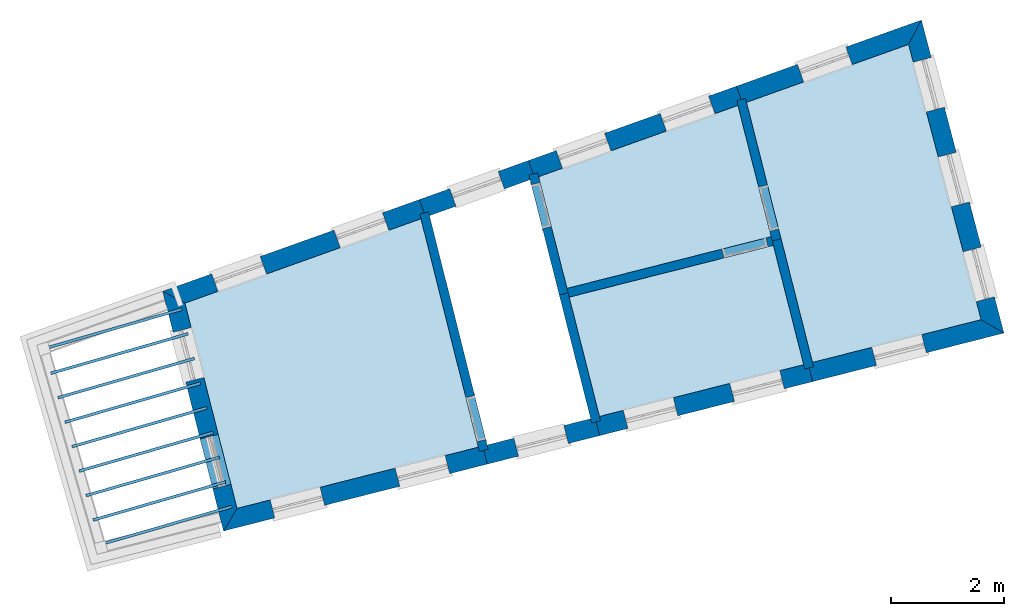
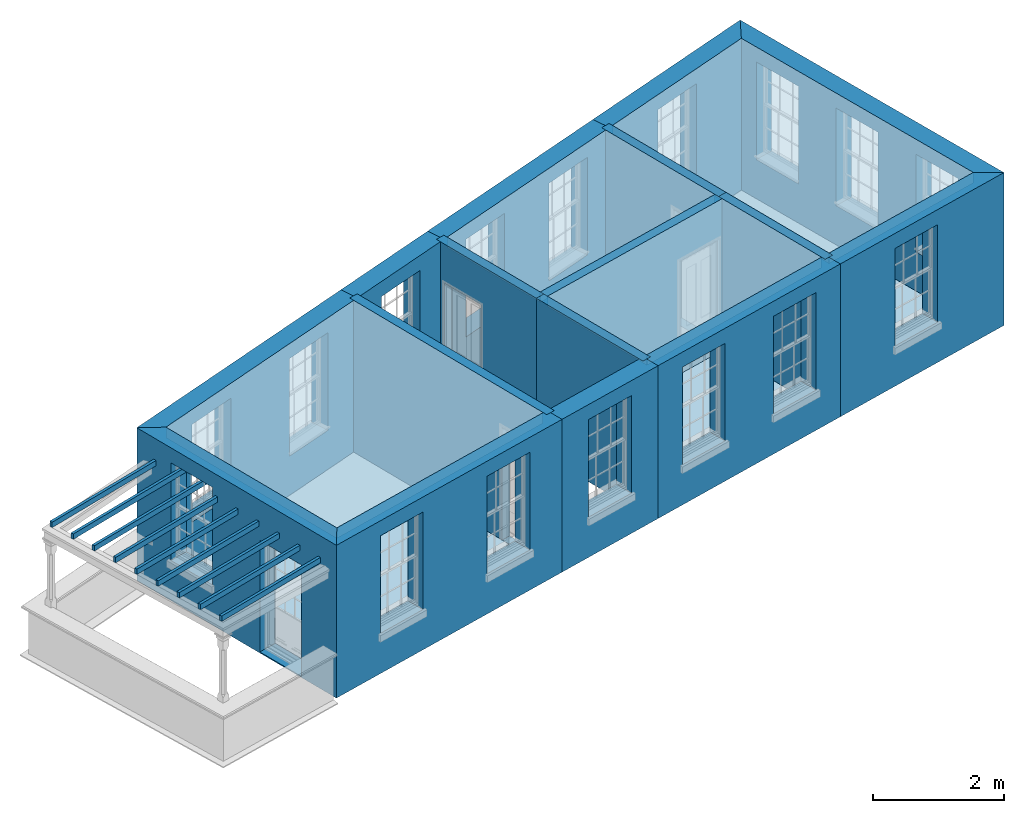
# One storey, part 1 of 11: 17 slabs, 16 walls, 21 openings.
"""IFC2X3 building model written with IfcOpenShell, lengths in metres."""

from ifc_helpers import new_model, si_unit, frame, origin, place, context, subcontext, project, spatial, polyline, outline, extrude, material, layer, layer_set, layer_usage, element, save


model = new_model("IFC2X3")

# Units and contexts
model_context = context("Model", 3, world=origin())
body_context = subcontext(model_context, "Body", "Model", "MODEL_VIEW")
ifc_project = project(units=[si_unit("PLANEANGLEUNIT", "RADIAN"), si_unit("MASSUNIT", "GRAM", prefix="KILO"), si_unit("FORCEUNIT", "NEWTON", prefix="KILO"), si_unit("LENGTHUNIT", "METRE")], contexts=[model_context])

# Site, building, storey
site_placement = place(None, origin())
site = spatial("IfcSite", under=ifc_project, at=site_placement, CompositionType="ELEMENT")
building_placement = place(None, origin())
building = spatial("IfcBuilding", under=site, at=building_placement, Name="Building plot-13", CompositionType="ELEMENT")
storey_placement = place(None, frame((0.0, 0.0, 6.7)))
storey = spatial("IfcBuildingStorey", under=building, at=storey_placement, Name="Floor 1", CompositionType="ELEMENT", Elevation=6.7)

# Slabs
slab_1_placement = place(storey_placement, frame((0.0, 0.0, 2.65)))
element("IfcSlab", 1, at=slab_1_placement, inside=storey, Name="Slab", ObjectType="Slab", PredefinedType="FLOOR", context=body_context, shape_type="SweptSolid", body=[
    extrude(outline(polyline([(72.1588295162765, 49.7758111334306), (72.6596473420581, 47.8011885201194), (76.2703797550893, 48.7169681452402), (75.6822868035305, 51.035698791588), (72.1588295162765, 49.7758111334306)])), origin(), (0.0, 0.0, 1.0), 0.2),
])
slab_2_placement = place(storey_placement, frame((0.0, 0.0, 2.65)))
element("IfcSlab", 2, at=slab_2_placement, inside=storey, Name="Slab", ObjectType="Slab", PredefinedType="FLOOR", context=body_context, shape_type="SweptSolid", body=[
    extrude(outline(polyline([(66.8267058597151, 43.9122434030099), (71.0924235909926, 44.9941450611672), (70.0791346157294, 49.0321716554071), (65.9065629771408, 47.5401792508866), (66.8267058597151, 43.9122434030099)])), origin(), (0.0, 0.0, 1.0), 0.2),
])
slab_3_placement = place(storey_placement, frame((0.0, 0.0, 2.65)))
element("IfcSlab", 3, at=slab_3_placement, inside=storey, Name="Slab", ObjectType="Slab", PredefinedType="FLOOR", context=body_context, shape_type="SweptSolid", body=[
    extrude(outline(polyline([(76.9996613749918, 46.4923807054943), (79.9817754258731, 47.2487256724398), (78.699089450727, 52.1144212259562), (75.8336276673544, 51.0898139605717), (76.9996613749918, 46.4923807054943)])), origin(), (0.0, 0.0, 1.0), 0.2),
])
slab_4_placement = place(storey_placement, frame((0.0, 0.0, 2.35)))
element("IfcSlab", 4, at=slab_4_placement, inside=storey, Name="Slab", ObjectType="Slab", PredefinedType="FLOOR", context=body_context, shape_type="SweptSolid", body=[
    extrude(outline(polyline([(63.4043941692164, 46.7569328166205), (63.418221467428, 46.7088827820298), (65.8576458623463, 47.4108728817339), (65.8438185641348, 47.4589229163246), (63.4043941692164, 46.7569328166205)])), origin(), (0.0, 0.0, 1.0), 0.1),
])
slab_5_placement = place(storey_placement, frame((0.0, 0.0, 2.35)))
element("IfcSlab", 5, at=slab_5_placement, inside=storey, Name="Slab", ObjectType="Slab", PredefinedType="FLOOR", context=body_context, shape_type="SweptSolid", body=[
    extrude(outline(polyline([(63.5288398531206, 46.3244825053042), (63.5426671513321, 46.2764324707135), (65.9683312902412, 46.9744627987977), (65.9545039920297, 47.0225128333884), (63.5288398531206, 46.3244825053042)])), origin(), (0.0, 0.0, 1.0), 0.1),
])
slab_6_placement = place(storey_placement, frame((0.0, 0.0, 2.35)))
element("IfcSlab", 6, at=slab_6_placement, inside=storey, Name="Slab", ObjectType="Slab", PredefinedType="FLOOR", context=body_context, shape_type="SweptSolid", body=[
    extrude(outline(polyline([(63.6532855370247, 45.8920321939878), (63.6671128352363, 45.8439821593971), (66.0790167181361, 46.5380527158614), (66.0651894199245, 46.5861027504521), (63.6532855370247, 45.8920321939878)])), origin(), (0.0, 0.0, 1.0), 0.1),
])
slab_7_placement = place(storey_placement, frame((0.0, 0.0, 2.35)))
element("IfcSlab", 7, at=slab_7_placement, inside=storey, Name="Slab", ObjectType="Slab", PredefinedType="FLOOR", context=body_context, shape_type="SweptSolid", body=[
    extrude(outline(polyline([(63.7777312209288, 45.4595818826714), (63.7915585191404, 45.4115318480807), (66.189702146031, 46.1016426329251), (66.1758748478194, 46.1496926675158), (63.7777312209288, 45.4595818826714)])), origin(), (0.0, 0.0, 1.0), 0.1),
])
slab_8_placement = place(storey_placement, frame((0.0, 0.0, 2.35)))
element("IfcSlab", 8, at=slab_8_placement, inside=storey, Name="Slab", ObjectType="Slab", PredefinedType="FLOOR", context=body_context, shape_type="SweptSolid", body=[
    extrude(outline(polyline([(63.902176904833, 45.027131571355), (63.9160042030445, 44.9790815367643), (66.3003875739259, 45.6652325499888), (66.2865602757143, 45.7132825845795), (63.902176904833, 45.027131571355)])), origin(), (0.0, 0.0, 1.0), 0.1),
])
slab_9_placement = place(storey_placement, frame((0.0, 0.0, 2.35)))
element("IfcSlab", 9, at=slab_9_placement, inside=storey, Name="Slab", ObjectType="Slab", PredefinedType="FLOOR", context=body_context, shape_type="SweptSolid", body=[
    extrude(outline(polyline([(64.0266225887371, 44.5946812600387), (64.0404498869487, 44.546631225448), (66.4110730018208, 45.2288224670526), (66.3972457036092, 45.2768725016433), (64.0266225887371, 44.5946812600387)])), origin(), (0.0, 0.0, 1.0), 0.1),
])
slab_10_placement = place(storey_placement, frame((0.0, 0.0, 2.35)))
element("IfcSlab", 10, at=slab_10_placement, inside=storey, Name="Slab", ObjectType="Slab", PredefinedType="FLOOR", context=body_context, shape_type="SweptSolid", body=[
    extrude(outline(polyline([(64.1510682726412, 44.1622309487223), (64.1648955708528, 44.1141809141316), (66.5217584297157, 44.7924123841163), (66.5079311315041, 44.840462418707), (64.1510682726412, 44.1622309487223)])), origin(), (0.0, 0.0, 1.0), 0.1),
])
slab_11_placement = place(storey_placement, frame((0.0, 0.0, 2.35)))
element("IfcSlab", 11, at=slab_11_placement, inside=storey, Name="Slab", ObjectType="Slab", PredefinedType="FLOOR", context=body_context, shape_type="SweptSolid", body=[
    extrude(outline(polyline([(64.2755139565454, 43.7297806374059), (64.2893412547569, 43.6817306028152), (66.6324438576106, 44.35600230118), (66.618616559399, 44.4040523357707), (64.2755139565454, 43.7297806374059)])), origin(), (0.0, 0.0, 1.0), 0.1),
])
slab_12_placement = place(storey_placement, frame((0.0, 0.0, 2.35)))
element("IfcSlab", 12, at=slab_12_placement, inside=storey, Name="Slab", ObjectType="Slab", PredefinedType="FLOOR", context=body_context, shape_type="SweptSolid", body=[
    extrude(outline(polyline([(64.3999596404495, 43.2973303260895), (64.4137869386611, 43.2492802914988), (66.7431292855055, 43.9195922182437), (66.7293019872939, 43.9676422528344), (64.3999596404495, 43.2973303260895)])), origin(), (0.0, 0.0, 1.0), 0.1),
])
slab_13_placement = place(storey_placement, frame((0.0, 0.0, 2.65)))
element("IfcSlab", 13, at=slab_13_placement, inside=storey, Name="Slab", ObjectType="Slab", PredefinedType="FLOOR", context=body_context, shape_type="SweptSolid", body=[
    extrude(outline(polyline([(72.6989822532658, 47.6460989822379), (73.2338394240791, 45.5372661691657), (76.8445718371103, 46.4530457942866), (76.309714666297, 48.5618786073587), (72.6989822532658, 47.6460989822379)])), origin(), (0.0, 0.0, 1.0), 0.2),
])
slab_14_placement = place(storey_placement, origin())
element("IfcSlab", 14, at=slab_14_placement, inside=storey, Name="Slab", ObjectType="Slab", PredefinedType="FLOOR", context=body_context, shape_type="SweptSolid", body=[
    extrude(outline(polyline([(72.1588295162765, 49.7758111334306), (72.6596473420581, 47.8011885201194), (76.2703797550893, 48.7169681452402), (75.6822868035305, 51.035698791588), (72.1588295162765, 49.7758111334306)])), origin(), (0.0, 0.0, 1.0), 0.02),
])
slab_15_placement = place(storey_placement, origin())
element("IfcSlab", 15, at=slab_15_placement, inside=storey, Name="Slab", ObjectType="Slab", PredefinedType="FLOOR", context=body_context, shape_type="SweptSolid", body=[
    extrude(outline(polyline([(66.8267058597151, 43.9122434030099), (71.0924235909926, 44.9941450611672), (70.0791346157294, 49.0321716554071), (65.9065629771408, 47.5401792508866), (66.8267058597151, 43.9122434030099)])), origin(), (0.0, 0.0, 1.0), 0.02),
])
slab_16_placement = place(storey_placement, origin())
element("IfcSlab", 16, at=slab_16_placement, inside=storey, Name="Slab", ObjectType="Slab", PredefinedType="FLOOR", context=body_context, shape_type="SweptSolid", body=[
    extrude(outline(polyline([(76.9996613749918, 46.4923807054943), (79.9817754258731, 47.2487256724398), (78.699089450727, 52.1144212259562), (75.8336276673544, 51.0898139605717), (76.9996613749918, 46.4923807054943)])), origin(), (0.0, 0.0, 1.0), 0.02),
])
slab_17_placement = place(storey_placement, origin())
element("IfcSlab", 17, at=slab_17_placement, inside=storey, Name="Slab", ObjectType="Slab", PredefinedType="FLOOR", context=body_context, shape_type="SweptSolid", body=[
    extrude(outline(polyline([(72.6989822532658, 47.6460989822379), (73.2338394240791, 45.5372661691657), (76.8445718371103, 46.4530457942866), (76.309714666297, 48.5618786073587), (72.6989822532658, 47.6460989822379)])), origin(), (0.0, 0.0, 1.0), 0.02),
])

# Wall, openings
ifc_material_1 = material(Name="Masonry")
ifc_layer_1 = layer(ifc_material_1, 0.33, ventilated=False)
ifc_layer_set_1 = layer_set([ifc_layer_1], Name="My Wall")
ifc_layer_usage_1 = layer_usage(ifc_layer_set_1, "AXIS2", "NEGATIVE", 0.08)
wall_1_placement = place(storey_placement, origin())
wall_1 = element("IfcWallStandardCase", 18, at=wall_1_placement, inside=storey, material=ifc_layer_usage_1, Name="exterior", context=body_context, shape_type="SweptSolid", body=[
    extrude(outline(polyline([(66.8267058597151, 43.9122434030099), (66.5879619422004, 43.5112429767636), (71.2509007169492, 44.6938906600119), (71.1697724625834, 45.0137628318924), (66.8267058597151, 43.9122434030099)])), origin(), (0.0, 0.0, 1.0), 2.85),
])
opening_1_placement = place(storey_placement, frame((0.0, 0.0, 0.75)))
element("IfcOpeningElement", 19, at=opening_1_placement, cuts=wall_1, Name="Opening", ObjectType="Opening", context=body_context, shape_type="SweptSolid", body=[
    extrude(outline(polyline([(67.494406314742, 43.7411418429004), (68.3764780614428, 43.964859150394), (68.295349807077, 44.2847313222745), (67.4132780603762, 44.0610140147809), (67.494406314742, 43.7411418429004)])), origin(), (0.0, 0.0, 1.0), 1.82),
])
opening_2_placement = place(storey_placement, frame((0.0, 0.0, 0.75)))
element("IfcOpeningElement", 20, at=opening_2_placement, cuts=wall_1, Name="Opening", ObjectType="Opening", context=body_context, shape_type="SweptSolid", body=[
    extrude(outline(polyline([(69.7047120006465, 44.3017352851435), (70.5867837473473, 44.5254525926372), (70.5056554929815, 44.8453247645177), (69.6235837462807, 44.621607457024), (69.7047120006465, 44.3017352851435)])), origin(), (0.0, 0.0, 1.0), 1.82),
])

# Wall, opening
wall_2_placement = place(storey_placement, origin())
wall_2 = element("IfcWallStandardCase", 21, at=wall_2_placement, inside=storey, material=ifc_layer_usage_1, Name="exterior", context=body_context, shape_type="SweptSolid", body=[
    extrude(outline(polyline([(71.1697724625834, 45.0137628318924), (71.2509007169492, 44.6938906600119), (73.2374229095042, 45.1977265416814), (73.1562946551384, 45.5175987135619), (71.1697724625834, 45.0137628318924)])), origin(), (0.0, 0.0, 1.0), 2.85),
])
opening_3_placement = place(storey_placement, frame((0.0, 0.0, 0.75)))
element("IfcOpeningElement", 22, at=opening_3_placement, cuts=wall_2, Name="Opening", ObjectType="Opening", context=body_context, shape_type="SweptSolid", body=[
    extrude(outline(polyline([(71.8031259398763, 44.8339499470999), (72.6851976865771, 45.0576672545935), (72.6040694322113, 45.377539426474), (71.7219976855105, 45.1538221189804), (71.8031259398763, 44.8339499470999)])), origin(), (0.0, 0.0, 1.0), 1.82),
])

# Wall, openings
wall_3_placement = place(storey_placement, origin())
wall_3 = element("IfcWallStandardCase", 23, at=wall_3_placement, inside=storey, material=ifc_layer_usage_1, Name="exterior", context=body_context, shape_type="SweptSolid", body=[
    extrude(outline(polyline([(73.1562946551384, 45.5175987135619), (73.2374229095042, 45.1977265416814), (77.0032448604169, 46.1528410780099), (76.9221166060511, 46.4727132498904), (73.1562946551384, 45.5175987135619)])), origin(), (0.0, 0.0, 1.0), 2.85),
])
opening_4_placement = place(storey_placement, frame((0.0, 0.0, 0.75)))
element("IfcOpeningElement", 24, at=opening_4_placement, cuts=wall_3, Name="Opening", ObjectType="Opening", context=body_context, shape_type="SweptSolid", body=[
    extrude(outline(polyline([(73.737842523882, 45.3246465220167), (74.6199142705828, 45.5483638295104), (74.5387860162169, 45.8682360013909), (73.6567142695161, 45.6445186938972), (73.737842523882, 45.3246465220167)])), origin(), (0.0, 0.0, 1.0), 1.82),
])
opening_5_placement = place(storey_placement, frame((0.0, 0.0, 0.75)))
element("IfcOpeningElement", 25, at=opening_5_placement, cuts=wall_3, Name="Opening", ObjectType="Opening", context=body_context, shape_type="SweptSolid", body=[
    extrude(outline(polyline([(75.6207534993383, 45.802203790181), (76.5028252460391, 46.0259210976746), (76.4216969916733, 46.3457932695551), (75.5396252449725, 46.1220759620615), (75.6207534993383, 45.802203790181)])), origin(), (0.0, 0.0, 1.0), 1.82),
])

# Wall, opening
wall_4_placement = place(storey_placement, origin())
wall_4 = element("IfcWallStandardCase", 26, at=wall_4_placement, inside=storey, material=ifc_layer_usage_1, Name="exterior", context=body_context, shape_type="SweptSolid", body=[
    extrude(outline(polyline([(76.9221166060511, 46.4727132498904), (77.0032448604169, 46.1528410780099), (80.3857854678444, 47.0107450750622), (79.9817754258731, 47.2487256724398), (76.9221166060511, 46.4727132498904)])), origin(), (0.0, 0.0, 1.0), 2.85),
])
opening_6_placement = place(storey_placement, frame((0.0, 0.0, 0.75)))
element("IfcOpeningElement", 27, at=opening_6_placement, cuts=wall_4, Name="Opening", ObjectType="Opening", context=body_context, shape_type="SweptSolid", body=[
    extrude(outline(polyline([(78.1311755833539, 46.4389148869927), (79.0132473300547, 46.6626321944863), (78.9321190756889, 46.9825043663668), (78.0500473289881, 46.7587870588732), (78.1311755833539, 46.4389148869927)])), origin(), (0.0, 0.0, 1.0), 1.82),
])

# Wall, openings
wall_5_placement = place(storey_placement, origin())
wall_5 = element("IfcWallStandardCase", 28, at=wall_5_placement, inside=storey, material=ifc_layer_usage_1, Name="exterior", context=body_context, shape_type="SweptSolid", body=[
    extrude(outline(polyline([(79.9817754258731, 47.2487256724398), (80.3857854678444, 47.0107450750622), (78.9265356735152, 52.5462115674965), (78.699089450727, 52.1144212259562), (79.9817754258731, 47.2487256724398)])), origin(), (0.0, 0.0, 1.0), 2.85),
])
opening_7_placement = place(storey_placement, frame((0.0, 0.0, 0.75)))
element("IfcOpeningElement", 29, at=opening_7_placement, cuts=wall_5, Name="Opening", ObjectType="Opening", context=body_context, shape_type="SweptSolid", body=[
    extrude(outline(polyline([(80.2165274414276, 47.6528024784256), (79.9845597414815, 48.5327405365761), (79.6654613247896, 48.4486203816506), (79.8974290247357, 47.5686823235001), (80.2165274414276, 47.6528024784256)])), origin(), (0.0, 0.0, 1.0), 1.82),
])
opening_8_placement = place(storey_placement, frame((0.0, 0.0, 0.75)))
element("IfcOpeningElement", 30, at=opening_8_placement, cuts=wall_5, Name="Opening", ObjectType="Opening", context=body_context, shape_type="SweptSolid", body=[
    extrude(outline(polyline([(79.7746976663439, 49.3288239004194), (79.5427299663978, 50.2087619585699), (79.2236315497059, 50.1246418036444), (79.455599249652, 49.2447037454939), (79.7746976663439, 49.3288239004194)])), origin(), (0.0, 0.0, 1.0), 1.82),
])
opening_9_placement = place(storey_placement, frame((0.0, 0.0, 0.75)))
element("IfcOpeningElement", 31, at=opening_9_placement, cuts=wall_5, Name="Opening", ObjectType="Opening", context=body_context, shape_type="SweptSolid", body=[
    extrude(outline(polyline([(79.3328678912602, 51.0048453224131), (79.1009001913141, 51.8847833805637), (78.7818017746222, 51.8006632256382), (79.0137694745683, 50.9207251674876), (79.3328678912602, 51.0048453224131)])), origin(), (0.0, 0.0, 1.0), 1.82),
])

# Wall, opening
wall_6_placement = place(storey_placement, origin())
wall_6 = element("IfcWallStandardCase", 32, at=wall_6_placement, inside=storey, material=ifc_layer_usage_1, Name="exterior", context=body_context, shape_type="SweptSolid", body=[
    extrude(outline(polyline([(78.699089450727, 52.1144212259562), (78.9265356735152, 52.5462115674965), (75.6540271002417, 51.3760559996695), (75.765136209946, 51.0653233722537), (78.699089450727, 52.1144212259562)])), origin(), (0.0, 0.0, 1.0), 2.85),
])
opening_10_placement = place(storey_placement, frame((0.0, 0.0, 0.75)))
element("IfcOpeningElement", 33, at=opening_10_placement, cuts=wall_6, Name="Opening", ObjectType="Opening", context=body_context, shape_type="SweptSolid", body=[
    extrude(outline(polyline([(77.5904751108561, 52.0684744825221), (76.7336063504065, 51.7620826951557), (76.8447154601108, 51.4513500677399), (77.7015842205604, 51.7577418551063), (77.5904751108561, 52.0684744825221)])), origin(), (0.0, 0.0, 1.0), 1.82),
])

# Wall, openings
wall_7_placement = place(storey_placement, origin())
wall_7 = element("IfcWallStandardCase", 34, at=wall_7_placement, inside=storey, material=ifc_layer_usage_1, Name="exterior", context=body_context, shape_type="SweptSolid", body=[
    extrude(outline(polyline([(75.765136209946, 51.0653233722537), (75.6540271002417, 51.3760559996695), (71.9792289491637, 50.0620531725284), (72.090338058868, 49.7513205451126), (75.765136209946, 51.0653233722537)])), origin(), (0.0, 0.0, 1.0), 2.85),
])
opening_11_placement = place(storey_placement, frame((0.0, 0.0, 0.75)))
element("IfcOpeningElement", 35, at=opening_11_placement, cuts=wall_7, Name="Opening", ObjectType="Opening", context=body_context, shape_type="SweptSolid", body=[
    extrude(outline(polyline([(75.163761942697, 51.2007511865675), (74.3068931822474, 50.894359399201), (74.4180022919517, 50.5836267717852), (75.2748710524013, 50.8900185591517), (75.163761942697, 51.2007511865675)])), origin(), (0.0, 0.0, 1.0), 1.82),
])
opening_12_placement = place(storey_placement, frame((0.0, 0.0, 0.75)))
element("IfcOpeningElement", 36, at=opening_12_placement, cuts=wall_7, Name="Opening", ObjectType="Opening", context=body_context, shape_type="SweptSolid", body=[
    extrude(outline(polyline([(73.326362867158, 50.5437497729969), (72.4694941067084, 50.2373579856305), (72.5806032164127, 49.9266253582147), (73.4374719768623, 50.2330171455811), (73.326362867158, 50.5437497729969)])), origin(), (0.0, 0.0, 1.0), 1.82),
])

# Wall, opening
wall_8_placement = place(storey_placement, origin())
wall_8 = element("IfcWallStandardCase", 37, at=wall_8_placement, inside=storey, material=ifc_layer_usage_1, Name="exterior", context=body_context, shape_type="SweptSolid", body=[
    extrude(outline(polyline([(72.090338058868, 49.7513205451126), (71.9792289491637, 50.0620531725284), (70.0510857180657, 49.3726042415572), (70.16219482777, 49.0618716141414), (72.090338058868, 49.7513205451126)])), origin(), (0.0, 0.0, 1.0), 2.85),
])
opening_13_placement = place(storey_placement, frame((0.0, 0.0, 0.75)))
element("IfcOpeningElement", 38, at=opening_13_placement, cuts=wall_8, Name="Opening", ObjectType="Opening", context=body_context, shape_type="SweptSolid", body=[
    extrude(outline(polyline([(71.4435917138395, 49.870524600726), (70.5867229533899, 49.5641328133596), (70.6978320630942, 49.2534001859438), (71.5547008235438, 49.5597919733102), (71.4435917138395, 49.870524600726)])), origin(), (0.0, 0.0, 1.0), 1.82),
])

# Wall, openings
wall_9_placement = place(storey_placement, origin())
wall_9 = element("IfcWallStandardCase", 39, at=wall_9_placement, inside=storey, material=ifc_layer_usage_1, Name="exterior", context=body_context, shape_type="SweptSolid", body=[
    extrude(outline(polyline([(70.16219482777, 49.0618716141414), (70.0510857180657, 49.3726042415572), (65.5129266056267, 47.7498882014907), (65.9065629771408, 47.5401792508866), (70.16219482777, 49.0618716141414)])), origin(), (0.0, 0.0, 1.0), 2.85),
])
opening_14_placement = place(storey_placement, frame((0.0, 0.0, 0.75)))
element("IfcOpeningElement", 40, at=opening_14_placement, cuts=wall_9, Name="Opening", ObjectType="Opening", context=body_context, shape_type="SweptSolid", body=[
    extrude(outline(polyline([(69.3984892712811, 49.1392543973472), (68.5416205108315, 48.8328626099808), (68.6527296205358, 48.522129982565), (69.5095983809854, 48.8285217699314), (69.3984892712811, 49.1392543973472)])), origin(), (0.0, 0.0, 1.0), 1.82),
])
opening_15_placement = place(storey_placement, frame((0.0, 0.0, 0.75)))
element("IfcOpeningElement", 41, at=opening_15_placement, cuts=wall_9, Name="Opening", ObjectType="Opening", context=body_context, shape_type="SweptSolid", body=[
    extrude(outline(polyline([(67.2364276172623, 48.3661629215608), (66.3795588568127, 48.0597711341944), (66.490667966517, 47.7490385067786), (67.3475367269666, 48.055430294145), (67.2364276172623, 48.3661629215608)])), origin(), (0.0, 0.0, 1.0), 1.82),
])

wall_10_placement = place(storey_placement, origin())
wall_10 = element("IfcWallStandardCase", 42, at=wall_10_placement, inside=storey, material=ifc_layer_usage_1, Name="exterior", context=body_context, shape_type="SweptSolid", body=[
    extrude(outline(polyline([(65.9065629771408, 47.5401792508866), (65.5129266056267, 47.7498882014907), (66.5879619422004, 43.5112429767636), (66.8267058597151, 43.9122434030099), (65.9065629771408, 47.5401792508866)])), origin(), (0.0, 0.0, 1.0), 2.85),
])
opening_16_placement = place(storey_placement, frame((0.0, 0.0, 0.75)))
element("IfcOpeningElement", 43, at=opening_16_placement, cuts=wall_10, Name="Opening", ObjectType="Opening", context=body_context, shape_type="SweptSolid", body=[
    extrude(outline(polyline([(65.6963730633974, 47.0265962074796), (65.920090370891, 46.1445244607788), (66.2399625427715, 46.2256527151446), (66.0162452352779, 47.1077244618454), (65.6963730633974, 47.0265962074796)])), origin(), (0.0, 0.0, 1.0), 1.82),
])
opening_17_placement = place(storey_placement, frame((0.0, 0.0, 0.0199999999999996)))
element("IfcOpeningElement", 44, at=opening_17_placement, cuts=wall_10, Name="Opening", ObjectType="Opening", context=body_context, shape_type="SweptSolid", body=[
    extrude(outline(polyline([(66.1752193475935, 45.1386029045291), (66.3989366550872, 44.2565311578283), (66.7188088269677, 44.3376594121941), (66.495091519474, 45.2197311588949), (66.1752193475935, 45.1386029045291)])), origin(), (0.0, 0.0, 1.0), 2.08),
])

# Wall, opening
ifc_material_2 = material(Name="Masonry")
ifc_layer_2 = layer(ifc_material_2, 0.16, ventilated=False)
ifc_layer_set_2 = layer_set([ifc_layer_2], Name="My Wall")
ifc_layer_usage_2 = layer_usage(ifc_layer_set_2, "AXIS2", "NEGATIVE", 0.08)
wall_11_placement = place(storey_placement, origin())
wall_11 = element("IfcWallStandardCase", 45, at=wall_11_placement, inside=storey, material=ifc_layer_usage_2, Name="interior", context=body_context, shape_type="SweptSolid", body=[
    extrude(outline(polyline([(71.1118456496785, 44.9167468150566), (71.267034186696, 44.9556893108468), (70.2128535545322, 49.1566719838343), (70.0576650175148, 49.1177294880441), (71.1118456496785, 44.9167468150566)])), origin(), (0.0, 0.0, 1.0), 2.85),
])
opening_18_placement = place(storey_placement, frame((0.0, 0.0, 0.0199999999999996)))
element("IfcOpeningElement", 46, at=opening_18_placement, cuts=wall_11, Name="Opening", ObjectType="Opening", context=body_context, shape_type="SweptSolid", body=[
    extrude(outline(polyline([(71.2232238789319, 45.1302764149915), (71.0285113999808, 45.9062191000789), (70.8733228629633, 45.8672766042887), (71.0680353419145, 45.0913339192013), (71.2232238789319, 45.1302764149915)])), origin(), (0.0, 0.0, 1.0), 2.1),
])

wall_12_placement = place(storey_placement, origin())
wall_12 = element("IfcWallStandardCase", 47, at=wall_12_placement, inside=storey, material=ifc_layer_usage_2, Name="interior", context=body_context, shape_type="SweptSolid", body=[
    extrude(outline(polyline([(76.2900472106932, 48.6394233762995), (76.4451367485746, 48.6787582875071), (75.8157454371402, 51.1603199496553), (75.6606558992588, 51.1209850384477), (76.2900472106932, 48.6394233762995)])), origin(), (0.0, 0.0, 1.0), 2.85),
])
opening_19_placement = place(storey_placement, frame((0.0, 0.0, 0.0199999999999996)))
element("IfcOpeningElement", 48, at=opening_19_placement, cuts=wall_12, Name="Opening", ObjectType="Opening", context=body_context, shape_type="SweptSolid", body=[
    extrude(outline(polyline([(76.400884973466, 48.8532340176238), (76.2042104174276, 49.6286817070311), (76.0491208795462, 49.5893467958234), (76.2457954355845, 48.8138991064161), (76.400884973466, 48.8532340176238)])), origin(), (0.0, 0.0, 1.0), 2.1),
])

# Wall
wall_13_placement = place(storey_placement, origin())
element("IfcWallStandardCase", 49, at=wall_13_placement, inside=storey, material=ifc_layer_usage_2, Name="interior", context=body_context, shape_type="SweptSolid", body=[
    extrude(outline(polyline([(72.6793147976619, 47.7236437511786), (72.5242252597805, 47.684308839971), (73.0984173418015, 45.4203864890174), (73.2535068796829, 45.459721400225), (72.6793147976619, 47.7236437511786)])), origin(), (0.0, 0.0, 1.0), 2.85),
])

# Wall, opening
wall_14_placement = place(storey_placement, origin())
wall_14 = element("IfcWallStandardCase", 50, at=wall_14_placement, inside=storey, material=ifc_layer_usage_2, Name="interior", context=body_context, shape_type="SweptSolid", body=[
    extrude(outline(polyline([(72.1409472860622, 49.8463171225142), (71.9858577481808, 49.8069822113066), (72.5242252597805, 47.684308839971), (72.6793147976619, 47.7236437511786), (72.1409472860622, 49.8463171225142)])), origin(), (0.0, 0.0, 1.0), 2.85),
])
opening_20_placement = place(storey_placement, frame((0.0, 0.0, 0.0199999999999996)))
element("IfcOpeningElement", 51, at=opening_20_placement, cuts=wall_14, Name="Opening", ObjectType="Opening", context=body_context, shape_type="SweptSolid", body=[
    extrude(outline(polyline([(72.0301095232894, 49.6325064811899), (72.2267840793278, 48.8570587917826), (72.3818736172093, 48.8963937029903), (72.1851990611709, 49.6718413923976), (72.0301095232894, 49.6325064811899)])), origin(), (0.0, 0.0, 1.0), 2.1),
])

wall_15_placement = place(storey_placement, origin())
wall_15 = element("IfcWallStandardCase", 52, at=wall_15_placement, inside=storey, material=ifc_layer_usage_2, Name="interior", context=body_context, shape_type="SweptSolid", body=[
    extrude(outline(polyline([(76.3872594352377, 48.5815460629626), (76.3479245240301, 48.736635600844), (72.5821025731174, 47.7815210645155), (72.621437484325, 47.6264315266341), (76.3872594352377, 48.5815460629626)])), origin(), (0.0, 0.0, 1.0), 2.85),
])
opening_21_placement = place(storey_placement, frame((0.0, 0.0, 0.0199999999999996)))
element("IfcOpeningElement", 53, at=opening_21_placement, cuts=wall_15, Name="Opening", ObjectType="Opening", context=body_context, shape_type="SweptSolid", body=[
    extrude(outline(polyline([(76.1734487939134, 48.6923838257354), (75.3980011045061, 48.495709269697), (75.4373360157138, 48.3406197318156), (76.2127837051211, 48.5372942878539), (76.1734487939134, 48.6923838257354)])), origin(), (0.0, 0.0, 1.0), 2.1),
])

# Wall
wall_16_placement = place(storey_placement, origin())
element("IfcWallStandardCase", 54, at=wall_16_placement, inside=storey, material=ifc_layer_usage_2, Name="interior", context=body_context, shape_type="SweptSolid", body=[
    extrude(outline(polyline([(76.4451367485746, 48.6787582875071), (76.2900472106932, 48.6394233762995), (76.8642392927142, 46.3755010253459), (77.0193288305956, 46.4148359365535), (76.4451367485746, 48.6787582875071)])), origin(), (0.0, 0.0, 1.0), 2.85),
])

save(model, "model.ifc")
